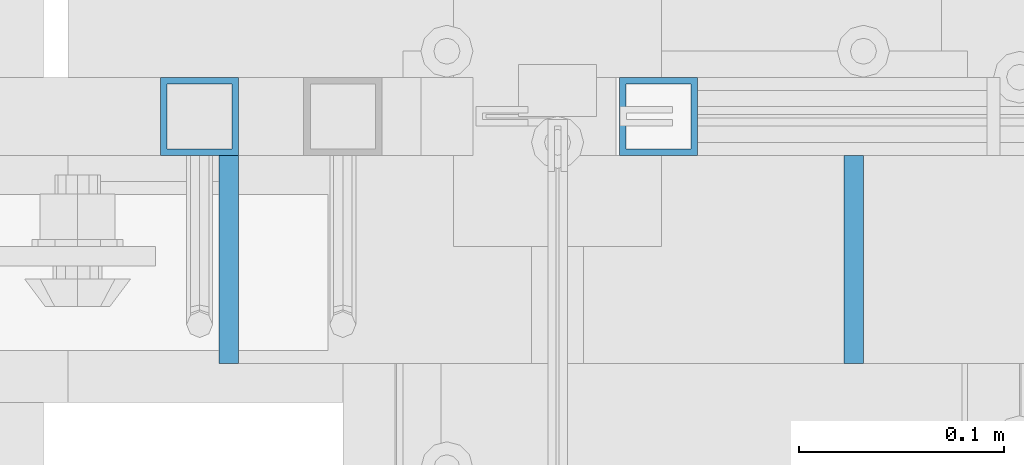
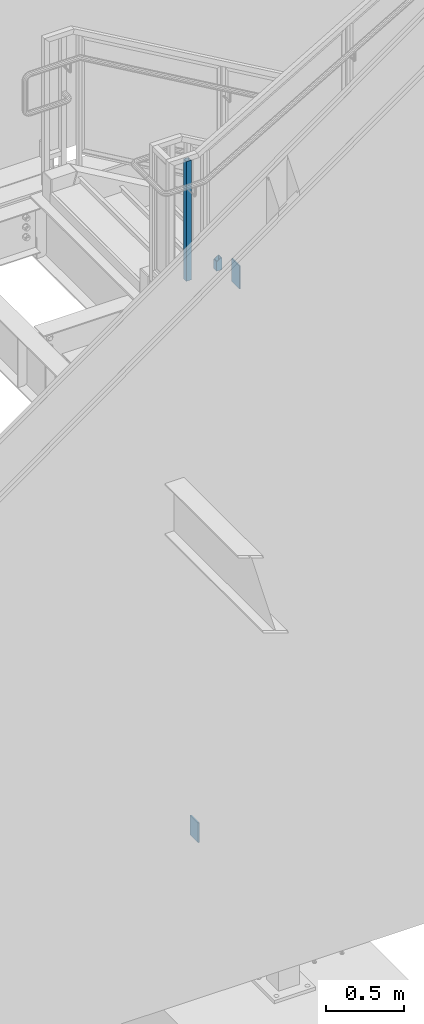
# One storey, part 566 of 1179: 4 columns, 3 elements without a shape of their own.
"""IFC2X3 building model written with IfcOpenShell, lengths in millimetres."""

from ifc_helpers import new_model, si_unit, frame, origin_with_axes, place, context, subcontext, project, spatial, faceted_brep, material, type_object, element, aggregate, save


model = new_model("IFC2X3")

# Units and contexts
model_context = context("Model", 3, precision=1e-05, world=origin_with_axes())
body_context = subcontext(model_context, "Body", "Model", "MODEL_VIEW")
ifc_project = project(units=[si_unit("LENGTHUNIT", "METRE", prefix="MILLI"), si_unit("AREAUNIT", "SQUARE_METRE"), si_unit("VOLUMEUNIT", "CUBIC_METRE"), si_unit("MASSUNIT", "GRAM", prefix="KILO"), si_unit("TIMEUNIT", "SECOND"), si_unit("PLANEANGLEUNIT", "RADIAN"), si_unit("SOLIDANGLEUNIT", "STERADIAN"), si_unit("THERMODYNAMICTEMPERATUREUNIT", "DEGREE_CELSIUS"), si_unit("LUMINOUSINTENSITYUNIT", "LUMEN")], contexts=[model_context])

# Site, building, storey
site_placement = place(None, origin_with_axes())
site = spatial("IfcSite", under=ifc_project, at=site_placement, CompositionType="ELEMENT")
building_placement = place(site_placement, origin_with_axes())
building = spatial("IfcBuilding", under=site, at=building_placement, Name="Undefined", CompositionType="ELEMENT")
storey_placement = place(building_placement, origin_with_axes())
storey = spatial("IfcBuildingStorey", under=building, at=storey_placement, Name="Undefined", CompositionType="ELEMENT", Elevation=0.0)

# Assembly, columns
assembly_1_placement = place(storey_placement, origin_with_axes())
assembly_1 = element("IfcElementAssembly", 1, at=assembly_1_placement, inside=storey, Name="GUARDRAIL", AssemblyPlace="NOTDEFINED", PredefinedType="RIGID_FRAME")
ifc_material_1 = material()
column_type_1 = type_object("IfcColumnType", Name="HSS1-1/2X1-1/2X1/8", PredefinedType="NOTDEFINED")
column_1_placement = place(assembly_1_placement, frame((19654.8374987511, 39471.5999992249, 4349.74999847), z_axis=(-1.0, 0.0, 0.0), x_axis=(0.0, 0.0, 1.0)))
column_1 = element("IfcColumn", 2, at=column_1_placement, type_object=column_type_1, material=ifc_material_1, Name="POST", ObjectType="HSS1-1/2X1-1/2X1/8", context=body_context, shape_type="Brep", body=[
    faceted_brep([(0.0, 15.8749992830017, -15.8749992829999), (0.0, -15.8749992830017, -15.8749992829999), (95.0578554542381, -15.874999282998, -15.8749992830017), (95.0578554542381, 15.874999282998, -15.8749992830017), (0.0, -15.8749992830017, 15.8749992829999), (76.5368762718172, -15.874999282998, 15.8749992830017), (0.0, 15.8749992830017, 15.8749992829999), (76.5368762718172, 15.874999282998, 15.8749992830017), (0.0, 19.0499992350015, -19.0499992349996), (0.0, 19.0499992350015, 19.0499992349996), (74.6847782979239, 19.0499992350015, 19.0499992350015), (96.9099534281304, 19.0499992350015, -19.0499992350015), (0.0, -19.0499992350015, 19.0499992349996), (74.6847782979239, -19.0499992350015, 19.0499992350015), (0.0, -19.0499992350015, -19.0499992349996), (96.9099534281304, -19.0499992350015, -19.0499992350015)], [[[0, 1, 2, 3]], [[1, 4, 5, 2]], [[4, 6, 7, 5]], [[6, 0, 3, 7]], [[8, 9, 10, 11]], [[9, 12, 13, 10]], [[12, 14, 15, 13]], [[14, 8, 11, 15]], [[13, 15, 11, 10], [5, 7, 3, 2]], [[14, 12, 9, 8], [6, 4, 1, 0]]]),
])
column_2_placement = place(assembly_1_placement, frame((19430.9999984545, 39471.5999992249, 4349.75), z_axis=(-1.0, 0.0, 0.0), x_axis=(0.0, 0.0, 1.0)))
column_2 = element("IfcColumn", 3, at=column_2_placement, type_object=column_type_1, material=ifc_material_1, Name="POST", ObjectType="HSS1-1/2X1-1/2X1/8", context=body_context, shape_type="Brep", body=[
    faceted_brep([(933.45, -19.0500000000029, 19.0499992350015), (933.45, -19.0499992350015, -19.0499992350015), (933.45, 19.0499992350015, -19.0499992350015), (933.45, 19.0499992350015, 19.0499992350015), (933.45, -15.874999282998, 15.8749992830017), (933.45, 15.874999282998, 15.8749992830017), (933.45, 15.874999282998, -15.8749992830017), (933.45, -15.874999282998, -15.8749992830017), (0.0, 19.0499992350015, 19.0499992349996), (0.0, -19.0499992350015, 19.0499992349996), (0.0, -19.0499992350015, -19.0499992349996), (0.0, 19.0499992350015, -19.0499992349996), (0.0, 15.8749992830017, 15.8749992829999), (0.0, -15.8749992830017, 15.8749992829999), (0.0, -15.8749992830017, -15.8749992829999), (0.0, 15.8749992830017, -15.8749992829999)], [[[0, 1, 2, 3], [4, 5, 6, 7]], [[8, 9, 0, 3]], [[10, 11, 2, 1]], [[9, 10, 1, 0]], [[11, 8, 3, 2]], [[10, 9, 8, 11], [12, 13, 14, 15]], [[14, 13, 4, 7]], [[15, 14, 7, 6]], [[12, 15, 6, 5]], [[13, 12, 5, 4]]]),
])
aggregate(assembly_1, [column_1, column_2])

# Assembly, column
assembly_2_placement = place(storey_placement, origin_with_axes())
assembly_2 = element("IfcElementAssembly", 4, at=assembly_2_placement, inside=storey, Name="STAIR", AssemblyPlace="NOTDEFINED", PredefinedType="RIGID_FRAME")
ifc_material_2 = material(Name="STEEL/A36")
column_type_2 = type_object("IfcColumnType", PredefinedType="NOTDEFINED")
column_3_placement = place(assembly_2_placement, frame((19445.2875, 39401.7499999842, 22.2911833333332), z_axis=(0.0, -1.0, 0.0), x_axis=(0.0, 0.0, 1.0)))
column_3 = element("IfcColumn", 5, at=column_3_placement, type_object=column_type_2, material=ifc_material_2, Name="PLATE", context=body_context, shape_type="Brep", body=[
    faceted_brep([(0.0, 4.76249999999982, -50.7999999999993), (0.0, 4.76249999999982, 50.7999999999993), (154.123330612203, 4.76250000000073, 50.8000000000029), (154.123330612203, 4.76250000000073, -50.8000000000029), (0.0, -4.76249999999982, 50.7999999999993), (154.123330612203, -4.76250000000073, 50.8000000000029), (0.0, -4.76249999999982, -50.7999999999993), (154.123330612203, -4.76250000000073, -50.8000000000029)], [[[0, 1, 2, 3]], [[1, 4, 5, 2]], [[4, 6, 7, 5]], [[6, 0, 3, 7]], [[5, 7, 3, 2]], [[6, 4, 1, 0]]]),
])
aggregate(assembly_2, [column_3])

assembly_3_placement = place(storey_placement, origin_with_axes())
assembly_3 = element("IfcElementAssembly", 6, at=assembly_3_placement, inside=storey, Name="STAIR", AssemblyPlace="NOTDEFINED", PredefinedType="RIGID_FRAME")
column_4_placement = place(assembly_3_placement, frame((19750.0874998126, 39401.7500000232, 4235.45000021773), z_axis=(0.0, -1.0, 0.0), x_axis=(0.0, 0.0, 1.0)))
column_4 = element("IfcColumn", 7, at=column_4_placement, type_object=column_type_2, material=ifc_material_2, Name="PLATE", context=body_context, shape_type="Brep", body=[
    faceted_brep([(0.0, 4.76249999999982, -50.7999999999993), (0.0, 4.76249999999982, 50.7999999999993), (177.572338034098, 4.76250000000073, 50.8000000000029), (177.572338034098, 4.76250000000073, -50.8000000000029), (0.0, -4.76249999999982, 50.7999999999993), (177.572338034098, -4.76250000000073, 50.8000000000029), (0.0, -4.76249999999982, -50.7999999999993), (177.572338034098, -4.76250000000073, -50.8000000000029)], [[[0, 1, 2, 3]], [[1, 4, 5, 2]], [[4, 6, 7, 5]], [[6, 0, 3, 7]], [[5, 7, 3, 2]], [[6, 4, 1, 0]]]),
])
aggregate(assembly_3, [column_4])

save(model, "model.ifc")
